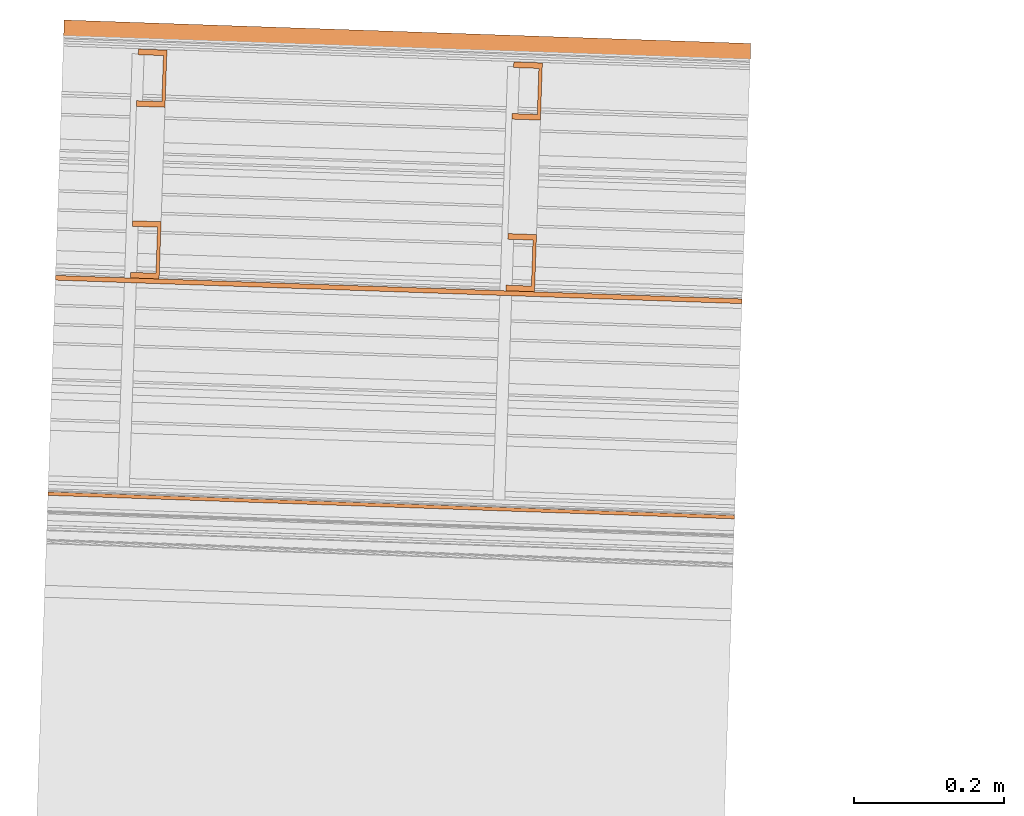
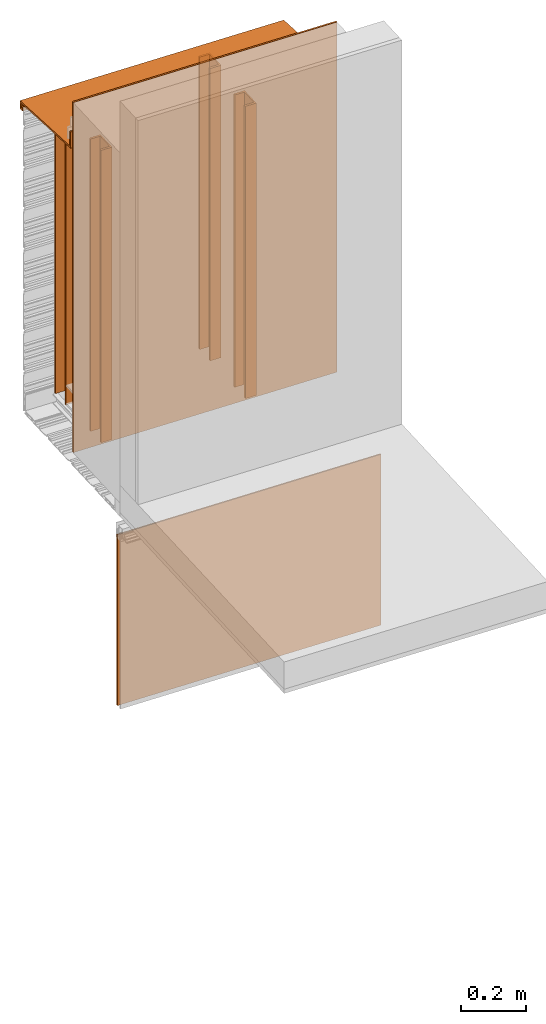
# One storey, part 2 of 6: 7 proxies.
"""IFC2X3 building model written with IfcOpenShell, lengths in feet."""

from ifc_helpers import new_model, entity, si_unit, converted_unit, derived_unit, direction, frame, frame_2d, origin, origin_2d_with_axis, place, context, subcontext, project, spatial, polyline, rectangle, outline, extrude, source, transform, mapped, material, type_object, type_shapes, element, save


model = new_model("IFC2X3")

# Units and contexts
model_context = context("Model", 3, precision=0.0001, world=origin(), true_north=direction((6.12303176911189e-17, 1.0)))
context_of_model = context(None, 3, precision=0.0001, world=origin(), true_north=direction((6.12303176911189e-17, 1.0)))
body_context = subcontext(model_context, "Body", "Model", "MODEL_VIEW")
ifc_project = project(units=[converted_unit("LENGTHUNIT", "FOOT", entity("IfcRatioMeasure", 0.3048), si_unit("LENGTHUNIT", "METRE"), dimensions=[1, 0, 0, 0, 0, 0, 0]), converted_unit("AREAUNIT", "SQUARE FOOT", entity("IfcRatioMeasure", 0.09290304), si_unit("AREAUNIT", "SQUARE_METRE"), dimensions=[2, 0, 0, 0, 0, 0, 0]), si_unit("VOLUMEUNIT", "CUBIC_METRE"), converted_unit("PLANEANGLEUNIT", "DEGREE", entity("IfcRatioMeasure", 0.0174532925199433), si_unit("PLANEANGLEUNIT", "RADIAN"), dimensions=[0, 0, 0, 0, 0, 0, 0]), si_unit("MASSUNIT", "GRAM", prefix="KILO"), derived_unit("MASSDENSITYUNIT", [(si_unit("MASSUNIT", "GRAM", prefix="KILO"), 1), (si_unit("LENGTHUNIT", "METRE"), -3)]), si_unit("TIMEUNIT", "SECOND"), si_unit("FREQUENCYUNIT", "HERTZ"), si_unit("THERMODYNAMICTEMPERATUREUNIT", "DEGREE_CELSIUS"), derived_unit("THERMALTRANSMITTANCEUNIT", [(si_unit("MASSUNIT", "GRAM", prefix="KILO"), 1), (si_unit("THERMODYNAMICTEMPERATUREUNIT", "KELVIN"), -1), (si_unit("TIMEUNIT", "SECOND"), -3)]), derived_unit("VOLUMETRICFLOWRATEUNIT", [(si_unit("LENGTHUNIT", "METRE"), 3), (si_unit("TIMEUNIT", "SECOND"), -1)]), si_unit("ELECTRICCURRENTUNIT", "AMPERE"), si_unit("ELECTRICVOLTAGEUNIT", "VOLT"), si_unit("POWERUNIT", "WATT"), si_unit("FORCEUNIT", "NEWTON"), si_unit("ILLUMINANCEUNIT", "LUX"), si_unit("LUMINOUSFLUXUNIT", "LUMEN"), si_unit("LUMINOUSINTENSITYUNIT", "CANDELA"), derived_unit("USERDEFINED", [(si_unit("MASSUNIT", "GRAM", prefix="KILO"), -1), (si_unit("LENGTHUNIT", "METRE"), -2), (si_unit("TIMEUNIT", "SECOND"), 3), (si_unit("LUMINOUSFLUXUNIT", "LUMEN"), 1)]), derived_unit("LINEARVELOCITYUNIT", [(si_unit("LENGTHUNIT", "METRE"), 1), (si_unit("TIMEUNIT", "SECOND"), -1)]), si_unit("PRESSUREUNIT", "PASCAL"), derived_unit("USERDEFINED", [(si_unit("LENGTHUNIT", "METRE"), -2), (si_unit("MASSUNIT", "GRAM", prefix="KILO"), 1), (si_unit("TIMEUNIT", "SECOND"), -2)])], contexts=[model_context, context_of_model])

# Site, building, storey
site_placement = place(None, origin())
site = spatial("IfcSite", under=ifc_project, at=site_placement, CompositionType="ELEMENT")
building_placement = place(site_placement, origin())
building = spatial("IfcBuilding", under=site, at=building_placement, CompositionType="ELEMENT")
storey_placement = place(building_placement, origin())
storey = spatial("IfcBuildingStorey", under=building, at=storey_placement, Name="Level 1", CompositionType="ELEMENT", Elevation=0.0)

# Proxies
ifc_material_1 = material(Name="METAL STUDS")
building_element_proxy_type_1 = type_object("IfcBuildingElementProxyType", Name="Metal stud 015", PredefinedType="NOTDEFINED", material=ifc_material_1)
shared_shape_1 = source(origin(), body_context, "Body", "SweptSolid", [
    extrude(outline(polyline([(-0.0661909448818871, -0.124999999999995), (0.0588090551181006, -0.124999999999995), (0.0588090551181176, -0.100393700787393), (-0.0514271653543104, -0.100393700787391), (-0.0514271653543313, 0.100393700787415), (0.0588090551181108, 0.100393700787414), (0.058809055118128, 0.12500000000001), (-0.0661909448818599, 0.125000000000017), (-0.0661909448818871, -0.124999999999995)])), frame((111.806856872744, -48.7923234996658, 9.875), z_axis=(0.0, 0.0, 1.0), x_axis=(-0.999414947916633, 0.0342017818365468, 0.0)), (0.0, 0.0, 1.0), 3.58333333333333),
])
type_shapes(building_element_proxy_type_1, [shared_shape_1])
proxy_1_placement = place(storey_placement, origin())
element("IfcBuildingElementProxy", 1, at=proxy_1_placement, inside=storey, type_object=building_element_proxy_type_1, material=ifc_material_1, Name="Metal stud 015:Metal stud 015", ObjectType="Metal stud 015", context=body_context, shape_type="MappedRepresentation", body=[
    mapped(shared_shape_1, transform((0.0, 0.0, 0.0), scale=1.0)),
])
building_element_proxy_type_2 = type_object("IfcBuildingElementProxyType", Name="Metal stud 016", PredefinedType="NOTDEFINED", material=ifc_material_1)
shared_shape_2 = source(origin(), body_context, "Body", "SweptSolid", [
    extrude(outline(polyline([(-0.0661909448819011, -0.125000000000003), (0.0588090551180867, -0.125000000000003), (0.0588090551181036, -0.1003937007874), (-0.0514271653543243, -0.100393700787399), (-0.0514271653543453, 0.100393700787407), (0.0588090551180971, 0.100393700787399), (0.0588090551181141, 0.125000000000002), (-0.0661909448818737, 0.125000000000002), (-0.0661909448819011, -0.125000000000003)])), frame((110.167396656345, -48.7362182145008, 9.875), z_axis=(0.0, 0.0, 1.0), x_axis=(-0.999414947916633, 0.0342017818365468, 0.0)), (0.0, 0.0, 1.0), 3.58333333333333),
])
type_shapes(building_element_proxy_type_2, [shared_shape_2])
proxy_2_placement = place(storey_placement, origin())
element("IfcBuildingElementProxy", 2, at=proxy_2_placement, inside=storey, type_object=building_element_proxy_type_2, material=ifc_material_1, Name="Metal stud 016:Metal stud 016", ObjectType="Metal stud 016", context=body_context, shape_type="MappedRepresentation", body=[
    mapped(shared_shape_2, transform((0.0, 0.0, 0.0), scale=1.0)),
])
building_element_proxy_type_3 = type_object("IfcBuildingElementProxyType", Name="Metal stud 010", PredefinedType="NOTDEFINED", material=ifc_material_1)
shared_shape_3 = source(origin(), body_context, "Body", "SweptSolid", [
    extrude(outline(polyline([(-0.0661909448818864, -0.125000000000003), (0.0588090551180871, -0.125000000000003), (0.0588090551181182, -0.100393700787399), (-0.0514271653543239, -0.100393700787399), (-0.0514271653543454, 0.1003937007874), (0.0588090551180967, 0.1003937007874), (0.0588090551181136, 0.125000000000002), (-0.0661909448818741, 0.125000000000002), (-0.0661909448818864, -0.125000000000003)])), frame((110.141745319968, -49.4857794254381, 9.875), z_axis=(0.0, 0.0, 1.0), x_axis=(-0.999414947916632, 0.0342017818365507, 0.0)), (0.0, 0.0, 1.0), 3.58333333333333),
])
type_shapes(building_element_proxy_type_3, [shared_shape_3])
proxy_3_placement = place(storey_placement, origin())
element("IfcBuildingElementProxy", 3, at=proxy_3_placement, inside=storey, type_object=building_element_proxy_type_3, material=ifc_material_1, Name="Metal stud 010:Metal stud 010", ObjectType="Metal stud 010", context=body_context, shape_type="MappedRepresentation", body=[
    mapped(shared_shape_3, transform((0.0, 0.0, 0.0), scale=1.0)),
])
building_element_proxy_type_4 = type_object("IfcBuildingElementProxyType", Name="Metal stud 009", PredefinedType="NOTDEFINED", material=ifc_material_1)
shared_shape_4 = source(origin(), body_context, "Body", "SweptSolid", [
    extrude(outline(polyline([(-0.0661909448818866, -0.125000000000009), (0.0588090551181011, -0.125000000000009), (0.0588090551181181, -0.100393700787407), (-0.0514271653543099, -0.100393700787406), (-0.0514271653543308, 0.1003937007874), (0.0588090551181113, 0.1003937007874), (0.0588090551181285, 0.124999999999995), (-0.0661909448818592, 0.124999999999995), (-0.0661909448818866, -0.125000000000009)])), frame((111.781205536366, -49.5418847106031, 9.875), z_axis=(0.0, 0.0, 1.0), x_axis=(-0.999414947916633, 0.0342017818365468, 0.0)), (0.0, 0.0, 1.0), 3.58333333333333),
])
type_shapes(building_element_proxy_type_4, [shared_shape_4])
proxy_4_placement = place(storey_placement, origin())
element("IfcBuildingElementProxy", 4, at=proxy_4_placement, inside=storey, type_object=building_element_proxy_type_4, material=ifc_material_1, Name="Metal stud 009:Metal stud 009", ObjectType="Metal stud 009", context=body_context, shape_type="MappedRepresentation", body=[
    mapped(shared_shape_4, transform((0.0, 0.0, 0.0), scale=1.0)),
])
ifc_material_2 = material(Name="IMPERMEABLE WRB MEMBRANE")
building_element_proxy_type_5 = type_object("IfcBuildingElementProxyType", Name="WRB Membrane 004", PredefinedType="NOTDEFINED", material=ifc_material_2)
shared_shape_5 = source(origin(), body_context, "Body", "SweptSolid", [
    extrude(rectangle(XDim=3.00000000000001, YDim=0.0208333332447324, at=origin_2d_with_axis()), frame((111.249569558505, -49.6591871078163, 9.87499999999999), z_axis=(0.0, 0.0, 1.0), x_axis=(-0.999414947916594, 0.0342017818376731, 0.0)), (0.0, 0.0, 1.0), 4.29166666666666),
])
type_shapes(building_element_proxy_type_5, [shared_shape_5])
proxy_5_placement = place(storey_placement, origin())
element("IfcBuildingElementProxy", 5, at=proxy_5_placement, inside=storey, type_object=building_element_proxy_type_5, material=ifc_material_2, Name="Membrane 004:Membrane 004", ObjectType="WRB Membrane 004", context=body_context, shape_type="MappedRepresentation", body=[
    mapped(shared_shape_5, transform((0.0, 0.0, 0.0), scale=1.0)),
])
ifc_material_3 = material(Name="SHEET METAL COPING")
building_element_proxy_type_6 = type_object("IfcBuildingElementProxyType", Name="Counter-flashing 003", PredefinedType="NOTDEFINED", material=ifc_material_3)
shared_shape_6 = source(origin(), body_context, "Body", "SweptSolid", [
    extrude(outline(polyline([(-0.122649832506564, -0.374644447526208), (-0.0243207540124679, -0.374644447526208), (0.0785724214419616, 0.687403667831295), (0.260425070602032, 0.687403667831295), (0.260425070602032, 0.708596612431124), (0.0592285252280149, 0.708596612431124), (-0.0436645732176864, -0.353447146017061), (-0.101456535928891, -0.353447146017061), (-0.101456535928891, -0.344552994114148), (-0.0712265118864845, -0.344552994114148), (-0.0712265118864845, -0.32335569260498), (-0.122649832506564, -0.32335569260498), (-0.122649832506564, -0.374644447526208)])), frame((109.776156128618, -48.8566384616609, 13.5125295948507), z_axis=(0.999414947916627, -0.0342017818367098, 0.0), x_axis=(0.0, 0.0, 1.0)), (0.0, 0.0, 1.0), 3.00000000000001),
])
type_shapes(building_element_proxy_type_6, [shared_shape_6])
proxy_6_placement = place(storey_placement, origin())
element("IfcBuildingElementProxy", 6, at=proxy_6_placement, inside=storey, type_object=building_element_proxy_type_6, material=ifc_material_3, Name="Counter-flashing 003:Counter-flashing 003", ObjectType="Counter-flashing 003", context=body_context, shape_type="MappedRepresentation", body=[
    mapped(shared_shape_6, transform((0.0, 0.0, 0.0), scale=1.0)),
])
ifc_material_4 = material(Name="Clear glass")
building_element_proxy_type_7 = type_object("IfcBuildingElementProxyType", Name="Glass panel 003", PredefinedType="NOTDEFINED", material=ifc_material_4)
shared_shape_7 = source(origin(), body_context, "Body", "SweptSolid", [
    extrude(rectangle(XDim=3.0, YDim=0.0156250000000221, at=frame_2d((-7.32747196252603e-15, 6.8590966240123e-15), x_axis=(1.0, 0.0))), frame((111.217317225848, -50.6016369343366, 7.3556443373819), z_axis=(0.0, 0.0, 1.0), x_axis=(-0.999414947916601, 0.0342017818374624, 0.0)), (0.0, 0.0, 1.0), 2.094323495),
])
type_shapes(building_element_proxy_type_7, [shared_shape_7])
proxy_7_placement = place(storey_placement, origin())
element("IfcBuildingElementProxy", 7, at=proxy_7_placement, inside=storey, type_object=building_element_proxy_type_7, material=ifc_material_4, Name="Glass panel 003:Glass panel 003", ObjectType="Glass panel 003", context=body_context, shape_type="MappedRepresentation", body=[
    mapped(shared_shape_7, transform((0.0, 0.0, 0.0), scale=1.0)),
])

save(model, "model.ifc")
